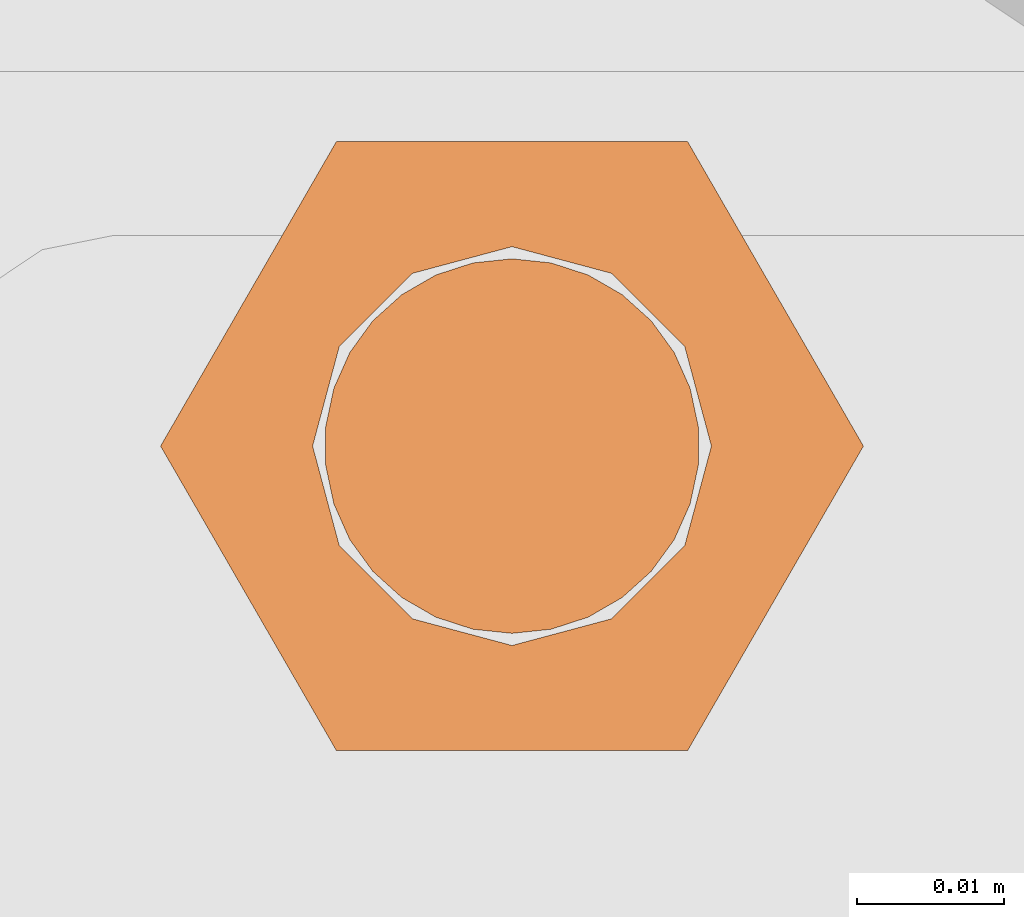
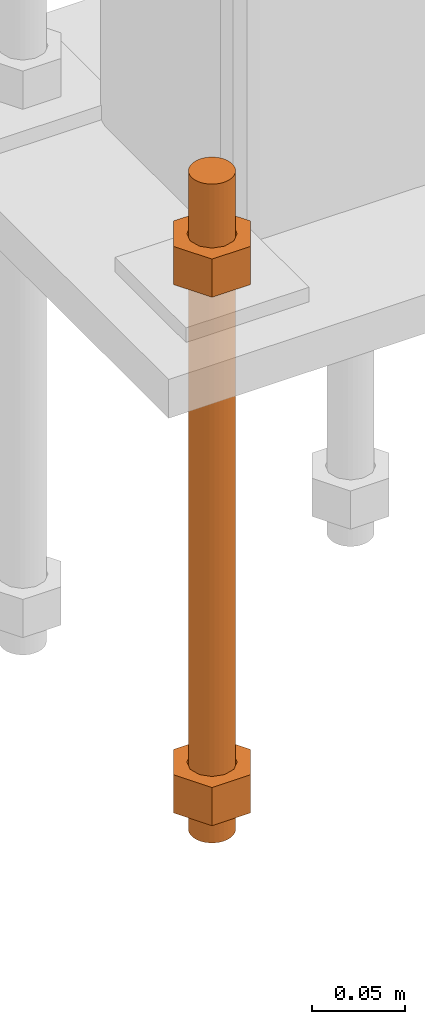
# One storey, part 27 of 89: 1 proxy.
"""IFC4 building model written with IfcOpenShell, lengths in feet."""

from ifc_helpers import new_model, entity, si_unit, converted_unit, derived_unit, direction, frame, origin, place, context, subcontext, project, spatial, faceted_brep, source, transform, mapped, material, constituent, constituent_set, type_object, type_shapes, element, save


model = new_model("IFC4")

# Units and contexts
model_context = context("Model", 3, precision=0.0001, world=origin(), true_north=direction((6.12303176911189e-17, 1.0)))
body_context = subcontext(model_context, "Body", "Model", "MODEL_VIEW")
ifc_project = project(units=[converted_unit("LENGTHUNIT", "FOOT", entity("IfcRatioMeasure", 0.3048), si_unit("LENGTHUNIT", "METRE"), dimensions=[1, 0, 0, 0, 0, 0, 0]), converted_unit("AREAUNIT", "SQUARE FOOT", entity("IfcRatioMeasure", 0.09290304), si_unit("AREAUNIT", "SQUARE_METRE"), dimensions=[2, 0, 0, 0, 0, 0, 0]), converted_unit("VOLUMEUNIT", "CUBIC FOOT", entity("IfcRatioMeasure", 0.028316846592), si_unit("VOLUMEUNIT", "CUBIC_METRE"), dimensions=[3, 0, 0, 0, 0, 0, 0]), si_unit("PLANEANGLEUNIT", "RADIAN"), si_unit("MASSUNIT", "GRAM", prefix="KILO"), derived_unit("MASSDENSITYUNIT", [(si_unit("MASSUNIT", "GRAM", prefix="KILO"), 1), (si_unit("LENGTHUNIT", "METRE"), -3)]), derived_unit("MOMENTOFINERTIAUNIT", [(si_unit("LENGTHUNIT", "METRE"), 4)]), si_unit("TIMEUNIT", "SECOND"), si_unit("FREQUENCYUNIT", "HERTZ"), si_unit("THERMODYNAMICTEMPERATUREUNIT", "DEGREE_CELSIUS"), derived_unit("THERMALTRANSMITTANCEUNIT", [(si_unit("MASSUNIT", "GRAM", prefix="KILO"), 1), (si_unit("THERMODYNAMICTEMPERATUREUNIT", "KELVIN"), -1), (si_unit("TIMEUNIT", "SECOND"), -3)]), derived_unit("VOLUMETRICFLOWRATEUNIT", [(si_unit("LENGTHUNIT", "METRE"), 3), (si_unit("TIMEUNIT", "SECOND"), -1)]), si_unit("ELECTRICCURRENTUNIT", "AMPERE"), si_unit("ELECTRICVOLTAGEUNIT", "VOLT"), si_unit("POWERUNIT", "WATT"), si_unit("FORCEUNIT", "NEWTON"), si_unit("ILLUMINANCEUNIT", "LUX"), si_unit("LUMINOUSFLUXUNIT", "LUMEN"), si_unit("LUMINOUSINTENSITYUNIT", "CANDELA"), derived_unit("USERDEFINED", [(si_unit("MASSUNIT", "GRAM", prefix="KILO"), -1), (si_unit("LENGTHUNIT", "METRE"), -2), (si_unit("TIMEUNIT", "SECOND"), 3), (si_unit("LUMINOUSFLUXUNIT", "LUMEN"), 1)]), derived_unit("LINEARVELOCITYUNIT", [(si_unit("LENGTHUNIT", "METRE"), 1), (si_unit("TIMEUNIT", "SECOND"), -1)]), si_unit("PRESSUREUNIT", "PASCAL"), derived_unit("USERDEFINED", [(si_unit("LENGTHUNIT", "METRE"), -2), (si_unit("MASSUNIT", "GRAM", prefix="KILO"), 1), (si_unit("TIMEUNIT", "SECOND"), -2)]), derived_unit("LINEARFORCEUNIT", [(si_unit("MASSUNIT", "GRAM", prefix="KILO"), 1), (si_unit("LENGTHUNIT", "METRE"), 1), (si_unit("TIMEUNIT", "SECOND"), -2), (si_unit("LENGTHUNIT", "METRE"), -1)]), derived_unit("PLANARFORCEUNIT", [(si_unit("MASSUNIT", "GRAM", prefix="KILO"), 1), (si_unit("LENGTHUNIT", "METRE"), 1), (si_unit("TIMEUNIT", "SECOND"), -2), (si_unit("LENGTHUNIT", "METRE"), -2)])], contexts=[model_context])

# Site, building, storey
site_placement = place(None, origin())
site = spatial("IfcSite", under=ifc_project, at=site_placement, CompositionType="ELEMENT")
building_placement = place(site_placement, frame((-472.238160486, -49.138065117, 0.0)))
building = spatial("IfcBuilding", under=site, at=building_placement, CompositionType="ELEMENT")
storey_placement = place(building_placement, origin())
storey = spatial("IfcBuildingStorey", under=building, at=storey_placement, Name="Level 1", CompositionType="ELEMENT", Elevation=0.0)

# Proxy
ifc_material_1 = material(Name="Color 7721", Category="Materials")
ifc_constituent_1 = constituent(ifc_material_1, Name="Color 7721", Category="Materials")
ifc_material_2 = material(Name="Color 7720", Category="Materials")
ifc_constituent_2 = constituent(ifc_material_2, Name="Color 7720", Category="Materials")
ifc_constituent_set = constituent_set(constituents=[ifc_constituent_1, ifc_constituent_2])
building_element_proxy_type = type_object("IfcBuildingElementProxyType", Name="rb2", PredefinedType="NOTDEFINED", material=ifc_material_1)
shared_shape = source(origin(), body_context, "Body", "Brep", [
    faceted_brep([(0.122545547339286, 0.0677083333333712, 0.0626666666666664), (0.156365697905557, 0.0677083333333712, 0.0626666666666664), (0.11727427342916, 0.135416666666742, 0.0626666666666664), (0.0390914244764247, 0.135416666666742, 0.0626666666666664), (0.0, 0.0677083333333712, 0.0626666666666664), (0.0338201505662994, 0.0677083333333712, 0.0626666666666664), (0.0397636251696838, 0.089889682526632, 0.0626666666666664), (0.0560014997595601, 0.106127557116452, 0.0626666666666664), (0.0781828489527925, 0.112071031719893, 0.0626666666666664), (0.100364198146025, 0.106127557116452, 0.0626666666666664), (0.116602072735901, 0.089889682526632, 0.0626666666666664), (0.11727427342916, 0.0, 0.0626666666666664), (0.0390914244764247, 0.0, 0.0626666666666664), (0.0397636251696838, 0.0455269841401105, 0.0626666666666664), (0.0560014997595601, 0.029289109550291, 0.0626666666666664), (0.0781828489527925, 0.0233456349468497, 0.0626666666666664), (0.100364198146025, 0.029289109550291, 0.0626666666666664), (0.116602072735901, 0.0455269841401105, 0.0626666666666664), (0.0, 0.0677083333333712, 0.144697916666667), (0.0390914244764531, 0.135416666666742, 0.144697916666667), (0.11727427342916, 0.135416666666742, 0.144697916666667), (0.156365697905585, 0.0677083333333712, 0.144697916666667), (0.117274273429189, 0.0, 0.144697916666667), (0.0390914244764247, 0.0, 0.144697916666667), (0.122545547339286, 0.0677083333333712, 0.144697916666666), (0.0338201505662994, 0.0677083333333712, 0.144697916666666), (0.0397636251696838, 0.0455269841401105, 0.144697916666666), (0.0560014997595601, 0.029289109550291, 0.144697916666666), (0.0781828489527925, 0.0233456349468497, 0.144697916666666), (0.100364198146025, 0.029289109550291, 0.144697916666666), (0.116602072735901, 0.0455269841401105, 0.144697916666666), (0.0397636251696838, 0.089889682526632, 0.144697916666666), (0.0560014997595601, 0.106127557116452, 0.144697916666666), (0.0781828489527925, 0.112071031719893, 0.144697916666666), (0.100364198146025, 0.106127557116452, 0.144697916666666), (0.116602072735901, 0.089889682526632, 0.144697916666666)], [[[0, 1, 2, 3, 4, 5, 6, 7, 8, 9, 10]], [[1, 11, 12, 4, 5, 13, 14, 15, 16, 17, 0]], [[4, 18, 19, 3]], [[3, 19, 20, 2]], [[2, 20, 21, 1]], [[1, 21, 22, 11]], [[11, 22, 23, 12]], [[12, 23, 18, 4]], [[24, 21, 22, 23, 18, 25, 26, 27, 28, 29, 30]], [[21, 20, 19, 18, 25, 31, 32, 33, 34, 35, 24]], [[25, 5, 6, 31]], [[31, 6, 7, 32]], [[32, 7, 8, 33]], [[33, 8, 9, 34]], [[34, 9, 10, 35]], [[35, 10, 0, 24]], [[24, 0, 17, 30]], [[30, 17, 16, 29]], [[29, 16, 15, 28]], [[28, 15, 14, 27]], [[27, 14, 13, 26]], [[26, 13, 5, 25]]]),
    faceted_brep([(0.0338201505662994, 0.0677083333333712, 1.28108333333333), (0.0, 0.0677083333333712, 1.28108333333333), (0.0390914244764247, 0.135416666666742, 1.28108333333333), (0.11727427342916, 0.135416666666742, 1.28108333333333), (0.156365697905557, 0.0677083333333712, 1.28108333333333), (0.122545547339286, 0.0677083333333712, 1.28108333333333), (0.116602072735901, 0.089889682526632, 1.28108333333333), (0.100364198146025, 0.106127557116452, 1.28108333333333), (0.0781828489527925, 0.112071031719893, 1.28108333333333), (0.0560014997595601, 0.106127557116452, 1.28108333333333), (0.0397636251696838, 0.089889682526632, 1.28108333333333), (0.0390914244764247, 0.0, 1.28108333333333), (0.11727427342916, 0.0, 1.28108333333333), (0.116602072735901, 0.0455269841401105, 1.28108333333333), (0.100364198146025, 0.029289109550291, 1.28108333333333), (0.0781828489527925, 0.0233456349468497, 1.28108333333333), (0.0560014997595601, 0.029289109550291, 1.28108333333333), (0.0397636251696838, 0.0455269841401105, 1.28108333333333), (0.156365697905528, 0.0677083333333712, 1.19905208333333), (0.117274273429132, 0.135416666666742, 1.19905208333333), (0.0390914244764247, 0.135416666666742, 1.19905208333333), (0.0, 0.0677083333333712, 1.19905208333333), (0.0390914244763962, 0.0, 1.19905208333333), (0.11727427342916, 0.0, 1.19905208333333), (0.0338201505662994, 0.0677083333333712, 1.19905208333333), (0.122545547339286, 0.0677083333333712, 1.19905208333333), (0.116602072735901, 0.0455269841401105, 1.19905208333333), (0.100364198146025, 0.029289109550291, 1.19905208333333), (0.0781828489527925, 0.0233456349468497, 1.19905208333333), (0.0560014997595601, 0.029289109550291, 1.19905208333333), (0.0397636251696838, 0.0455269841401105, 1.19905208333333), (0.116602072735901, 0.089889682526632, 1.19905208333333), (0.100364198146025, 0.106127557116452, 1.19905208333333), (0.0781828489527925, 0.112071031719893, 1.19905208333333), (0.0560014997595601, 0.106127557116452, 1.19905208333333), (0.0397636251696838, 0.089889682526632, 1.19905208333333)], [[[0, 1, 2, 3, 4, 5, 6, 7, 8, 9, 10]], [[1, 11, 12, 4, 5, 13, 14, 15, 16, 17, 0]], [[4, 18, 19, 3]], [[3, 19, 20, 2]], [[2, 20, 21, 1]], [[1, 21, 22, 11]], [[11, 22, 23, 12]], [[12, 23, 18, 4]], [[24, 21, 22, 23, 18, 25, 26, 27, 28, 29, 30]], [[21, 20, 19, 18, 25, 31, 32, 33, 34, 35, 24]], [[25, 5, 6, 31]], [[31, 6, 7, 32]], [[32, 7, 8, 33]], [[33, 8, 9, 34]], [[34, 9, 10, 35]], [[35, 10, 0, 24]], [[24, 0, 17, 30]], [[30, 17, 16, 29]], [[29, 16, 15, 28]], [[28, 15, 14, 27]], [[27, 14, 13, 26]], [[26, 13, 5, 25]]]),
    faceted_brep([(0.0781828489527925, 0.0260416666667425, 0.0), (0.0695198618353743, 0.0269521833027966, 0.0), (0.0612354888246216, 0.029643939264929, 0.0), (0.0536917967739328, 0.0339992919010683, 0.0), (0.0472184812245757, 0.0398278914017283, 0.0), (0.0420984571284464, 0.046875, 0.0), (0.0385554941071575, 0.0548326252344395, 0.0), (0.0367444366457903, 0.0633529806972319, 0.0), (0.0367444366457903, 0.0720636859695105, 0.0), (0.0385554941071575, 0.0805840414323029, 0.0), (0.0420984571284464, 0.0885416666667425, 0.0), (0.0472184812245757, 0.0955887752650142, 0.0), (0.0536917967739328, 0.101417374765674, 0.0), (0.0612354888246216, 0.105772727401813, 0.0), (0.0695198618353743, 0.108464483363946, 0.0), (0.0781828489527925, 0.109375, 0.0), (0.0868458360702107, 0.108464483363946, 0.0), (0.0951302090809634, 0.105772727401813, 0.0), (0.102673901131652, 0.101417374765674, 0.0), (0.109147216681009, 0.0955887752650142, 0.0), (0.114267240777139, 0.0885416666667425, 0.0), (0.117810203798427, 0.0805840414323029, 0.0), (0.119621261259795, 0.0720636859695105, 0.0), (0.119621261259795, 0.0633529806972319, 0.0), (0.117810203798427, 0.0548326252344395, 0.0), (0.114267240777139, 0.046875, 0.0), (0.109147216681009, 0.0398278914017283, 0.0), (0.102673901131652, 0.0339992919010683, 0.0), (0.0951302090809634, 0.029643939264929, 0.0), (0.0868458360702107, 0.0269521833027966, 0.0), (0.0868458360702107, 0.0269521833027966, 1.41666666666667), (0.0951302090809634, 0.029643939264929, 1.41666666666667), (0.102673901131652, 0.0339992919010683, 1.41666666666667), (0.109147216681009, 0.0398278914017283, 1.41666666666667), (0.114267240777139, 0.046875, 1.41666666666667), (0.117810203798427, 0.0548326252344395, 1.41666666666667), (0.119621261259795, 0.0633529806972319, 1.41666666666667), (0.119621261259795, 0.0720636859695105, 1.41666666666667), (0.117810203798427, 0.0805840414323029, 1.41666666666667), (0.114267240777139, 0.0885416666667425, 1.41666666666667), (0.109147216681009, 0.0955887752650142, 1.41666666666667), (0.102673901131652, 0.101417374765674, 1.41666666666667), (0.0951302090809634, 0.105772727401813, 1.41666666666667), (0.0868458360702107, 0.108464483363946, 1.41666666666667), (0.0781828489527925, 0.109375, 1.41666666666667), (0.0695198618353743, 0.108464483363946, 1.41666666666667), (0.0612354888246216, 0.105772727401813, 1.41666666666667), (0.0536917967739328, 0.101417374765674, 1.41666666666667), (0.0472184812245757, 0.0955887752650142, 1.41666666666667), (0.0420984571284464, 0.0885416666667425, 1.41666666666667), (0.0385554941071575, 0.0805840414323029, 1.41666666666667), (0.0367444366457903, 0.0720636859695105, 1.41666666666667), (0.0367444366457903, 0.0633529806972319, 1.41666666666667), (0.0385554941071575, 0.0548326252344395, 1.41666666666667), (0.0420984571284464, 0.046875, 1.41666666666667), (0.0472184812245757, 0.0398278914017283, 1.41666666666667), (0.0536917967739328, 0.0339992919010683, 1.41666666666667), (0.0612354888246216, 0.029643939264929, 1.41666666666667), (0.0695198618353743, 0.0269521833027966, 1.41666666666667), (0.0781828489527925, 0.0260416666667425, 1.41666666666667), (0.0695198618353743, 0.0269521833027966, 0.25), (0.0781828489527925, 0.0260416666667425, 0.25), (0.0612354888246216, 0.029643939264929, 0.25), (0.0536917967739328, 0.0339992919010683, 0.25), (0.0472184812246041, 0.0398278914017283, 0.25), (0.0420984571284464, 0.046875, 0.25), (0.0385554941071575, 0.0548326252344395, 0.25), (0.0367444366457903, 0.0633529806972319, 0.25), (0.0367444366457903, 0.0720636859695105, 0.25), (0.0385554941071291, 0.0805840414323029, 0.25), (0.0420984571284464, 0.0885416666667425, 0.25), (0.0472184812245757, 0.0955887752650142, 0.25), (0.0536917967739896, 0.101417374765674, 0.25), (0.0612354888246216, 0.105772727401813, 0.25), (0.0695198618353743, 0.108464483363946, 0.25), (0.0781828489527925, 0.109375, 0.25), (0.0868458360702107, 0.108464483363946, 0.25), (0.0951302090809634, 0.105772727401813, 0.25), (0.102673901131652, 0.101417374765674, 0.25), (0.109147216681066, 0.0955887752650142, 0.25), (0.114267240777139, 0.0885416666667425, 0.25), (0.117810203798371, 0.0805840414323029, 0.25), (0.119621261259766, 0.0720636859695105, 0.25), (0.119621261259795, 0.0633529806972319, 0.25), (0.117810203798427, 0.0548326252344395, 0.25), (0.114267240777195, 0.046875, 0.25), (0.109147216681009, 0.0398278914017283, 0.25), (0.102673901131681, 0.0339992919010683, 0.25), (0.0951302090809634, 0.029643939264929, 0.25), (0.0868458360702107, 0.0269521833027966, 0.25), (0.0695198618353743, 0.0269521833027966, 0.916666666666667), (0.0781828489527925, 0.0260416666667425, 0.916666666666667), (0.0612354888246216, 0.029643939264929, 0.916666666666667), (0.0536917967739328, 0.0339992919010683, 0.916666666666667), (0.0472184812246041, 0.0398278914017283, 0.916666666666667), (0.0420984571284464, 0.046875, 0.916666666666667), (0.0385554941071575, 0.0548326252344395, 0.916666666666667), (0.0367444366457903, 0.0633529806972319, 0.916666666666667), (0.0367444366457903, 0.0720636859695105, 0.916666666666667), (0.0385554941071291, 0.0805840414323029, 0.916666666666667), (0.0420984571284464, 0.0885416666667425, 0.916666666666667), (0.0472184812245757, 0.0955887752650142, 0.916666666666667), (0.0536917967739896, 0.101417374765674, 0.916666666666667), (0.0612354888246216, 0.105772727401813, 0.916666666666667), (0.0695198618353743, 0.108464483363946, 0.916666666666667), (0.0781828489527925, 0.109375, 0.916666666666667), (0.0868458360702107, 0.108464483363946, 0.916666666666667), (0.0951302090809634, 0.105772727401813, 0.916666666666667), (0.102673901131652, 0.101417374765674, 0.916666666666667), (0.109147216681066, 0.0955887752650142, 0.916666666666667), (0.114267240777139, 0.0885416666667425, 0.916666666666667), (0.117810203798371, 0.0805840414323029, 0.916666666666667), (0.119621261259766, 0.0720636859695105, 0.916666666666667), (0.119621261259795, 0.0633529806972319, 0.916666666666667), (0.117810203798427, 0.0548326252344395, 0.916666666666667), (0.114267240777195, 0.046875, 0.916666666666667), (0.109147216681009, 0.0398278914017283, 0.916666666666667), (0.102673901131681, 0.0339992919010683, 0.916666666666667), (0.0951302090809634, 0.029643939264929, 0.916666666666667), (0.0868458360702107, 0.0269521833027966, 0.916666666666667)], [[[0, 1, 2, 3, 4, 5, 6, 7, 8, 9, 10, 11, 12, 13, 14, 15, 16, 17, 18, 19, 20, 21, 22, 23, 24, 25, 26, 27, 28, 29]], [[30, 31, 32, 33, 34, 35, 36, 37, 38, 39, 40, 41, 42, 43, 44, 45, 46, 47, 48, 49, 50, 51, 52, 53, 54, 55, 56, 57, 58, 59]], [[60, 1, 0, 61]], [[62, 2, 1, 60]], [[63, 3, 2, 62]], [[64, 4, 3, 63]], [[65, 5, 4, 64]], [[66, 6, 5, 65]], [[67, 7, 6, 66]], [[68, 8, 7, 67]], [[69, 9, 8, 68]], [[70, 10, 9, 69]], [[71, 11, 10, 70]], [[72, 12, 11, 71]], [[73, 13, 12, 72]], [[74, 14, 13, 73]], [[75, 15, 14, 74]], [[76, 16, 15, 75]], [[77, 17, 16, 76]], [[78, 18, 17, 77]], [[79, 19, 18, 78]], [[80, 20, 19, 79]], [[81, 21, 20, 80]], [[82, 22, 21, 81]], [[83, 23, 22, 82]], [[84, 24, 23, 83]], [[85, 25, 24, 84]], [[86, 26, 25, 85]], [[87, 27, 26, 86]], [[88, 28, 27, 87]], [[89, 29, 28, 88]], [[61, 0, 29, 89]], [[90, 60, 61, 91]], [[92, 62, 60, 90]], [[93, 63, 62, 92]], [[94, 64, 63, 93]], [[95, 65, 64, 94]], [[96, 66, 65, 95]], [[97, 67, 66, 96]], [[98, 68, 67, 97]], [[99, 69, 68, 98]], [[100, 70, 69, 99]], [[101, 71, 70, 100]], [[102, 72, 71, 101]], [[103, 73, 72, 102]], [[104, 74, 73, 103]], [[105, 75, 74, 104]], [[106, 76, 75, 105]], [[107, 77, 76, 106]], [[108, 78, 77, 107]], [[109, 79, 78, 108]], [[110, 80, 79, 109]], [[111, 81, 80, 110]], [[112, 82, 81, 111]], [[113, 83, 82, 112]], [[114, 84, 83, 113]], [[115, 85, 84, 114]], [[116, 86, 85, 115]], [[117, 87, 86, 116]], [[118, 88, 87, 117]], [[119, 89, 88, 118]], [[91, 61, 89, 119]], [[58, 90, 91, 59]], [[57, 92, 90, 58]], [[56, 93, 92, 57]], [[55, 94, 93, 56]], [[54, 95, 94, 55]], [[53, 96, 95, 54]], [[52, 97, 96, 53]], [[51, 98, 97, 52]], [[50, 99, 98, 51]], [[49, 100, 99, 50]], [[48, 101, 100, 49]], [[47, 102, 101, 48]], [[46, 103, 102, 47]], [[45, 104, 103, 46]], [[44, 105, 104, 45]], [[43, 106, 105, 44]], [[42, 107, 106, 43]], [[41, 108, 107, 42]], [[40, 109, 108, 41]], [[39, 110, 109, 40]], [[38, 111, 110, 39]], [[37, 112, 111, 38]], [[36, 113, 112, 37]], [[35, 114, 113, 36]], [[34, 115, 114, 35]], [[33, 116, 115, 34]], [[32, 117, 116, 33]], [[31, 118, 117, 32]], [[30, 119, 118, 31]], [[59, 91, 119, 30]]]),
])
type_shapes(building_element_proxy_type, [shared_shape])
proxy_placement = place(building_placement, frame((199.588483817714, 999.598958333333, -1.45833333333333)))
element("IfcBuildingElementProxy", 1, at=proxy_placement, inside=storey, type_object=building_element_proxy_type, material=ifc_constituent_set, Name="rb2 360:rb2 360", ObjectType="rb2 360:rb2 360", PredefinedType="NOTDEFINED", context=body_context, shape_type="MappedRepresentation", body=[
    mapped(shared_shape, transform((0.0, 0.0, 0.0), scale=1.0)),
])

save(model, "model.ifc")
